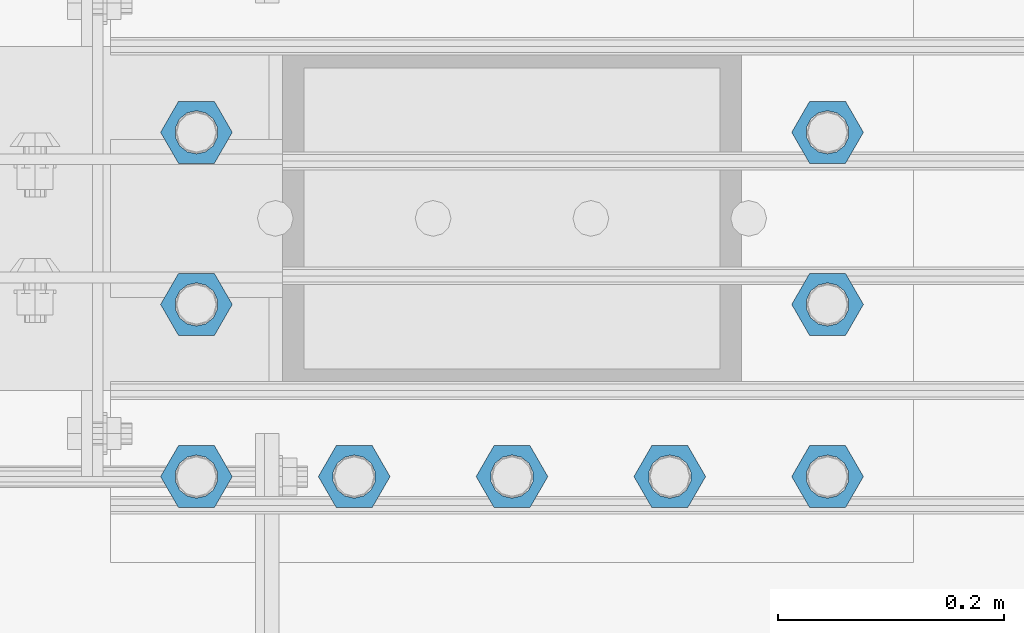
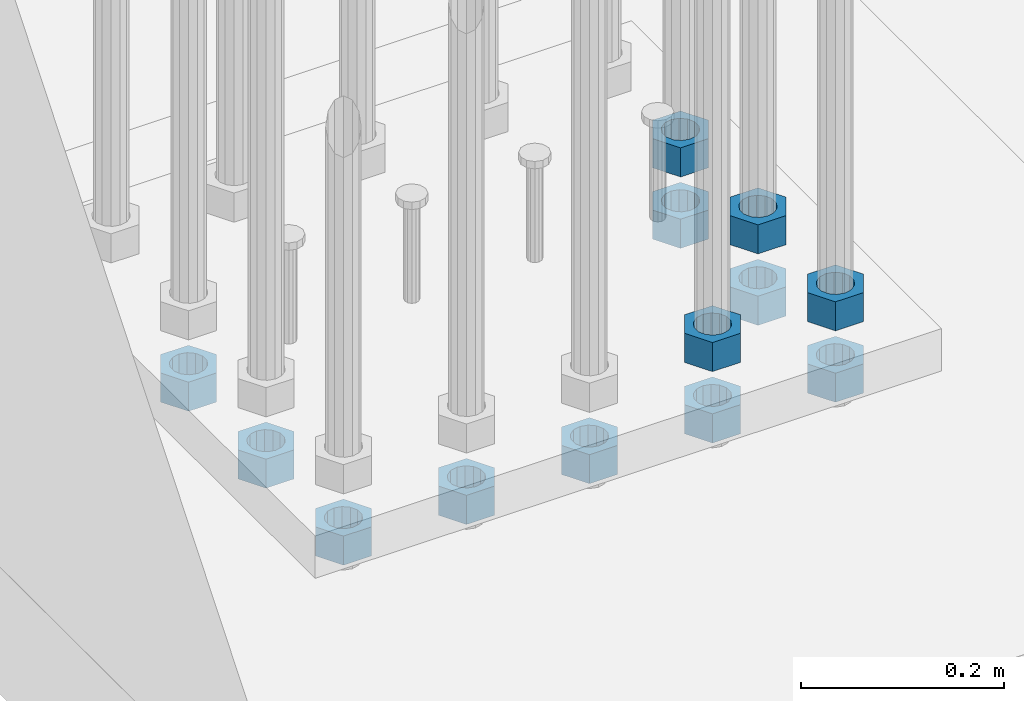
# One storey, part 1369 of 1876: 13 beams, 1 element without a shape of its own.
"""IFC2X3 building model written with IfcOpenShell, lengths in millimetres."""

from ifc_helpers import new_model, si_unit, frame, origin_with_axes, place, context, subcontext, project, spatial, faceted_brep, material, type_object, element, aggregate, save


model = new_model("IFC2X3")

# Units and contexts
model_context = context("Model", 3, precision=1e-05, world=origin_with_axes())
body_context = subcontext(model_context, "Body", "Model", "MODEL_VIEW")
ifc_project = project(units=[si_unit("LENGTHUNIT", "METRE", prefix="MILLI"), si_unit("AREAUNIT", "SQUARE_METRE"), si_unit("VOLUMEUNIT", "CUBIC_METRE"), si_unit("MASSUNIT", "GRAM", prefix="KILO"), si_unit("TIMEUNIT", "SECOND"), si_unit("PLANEANGLEUNIT", "RADIAN"), si_unit("SOLIDANGLEUNIT", "STERADIAN"), si_unit("THERMODYNAMICTEMPERATUREUNIT", "DEGREE_CELSIUS"), si_unit("LUMINOUSINTENSITYUNIT", "LUMEN")], contexts=[model_context])

# Site, building, storey
site_placement = place(None, origin_with_axes())
site = spatial("IfcSite", under=ifc_project, at=site_placement, CompositionType="ELEMENT")
building_placement = place(site_placement, origin_with_axes())
building = spatial("IfcBuilding", under=site, at=building_placement, Name="Undefined", CompositionType="ELEMENT")
storey_placement = place(building_placement, origin_with_axes())
storey = spatial("IfcBuildingStorey", under=building, at=storey_placement, Name="Undefined", CompositionType="ELEMENT", Elevation=0.0)

# Assembly, beams
assembly_placement = place(storey_placement, origin_with_axes())
assembly = element("IfcElementAssembly", 1, at=assembly_placement, inside=storey, Name="PLATE", AssemblyPlace="NOTDEFINED", PredefinedType="RIGID_FRAME")
ifc_material = material(Name="STEEL/A563")
beam_type = type_object("IfcBeamType", Name="1-3/8_HEAVY_HEX_NUT", PredefinedType="NOTDEFINED")
beam_1_placement = place(assembly_placement, frame((371.474990844726, -18313.3999755859, -701.675000762938), z_axis=(0.0, -1.0, 0.0), x_axis=(0.0, 0.0, -1.0)))
beam_1 = element("IfcBeam", 2, at=beam_1_placement, type_object=beam_type, material=ifc_material, Name="NUT", ObjectType="1-3/8_HEAVY_HEX_NUT", context=body_context, shape_type="Brep", body=[
    faceted_brep([(0.0, -31.75, 0.0), (0.0, -15.8800001144409, -27.5), (34.925, -15.8800001144409, -27.5), (34.925, -31.75, 0.0), (0.0, 15.8800001144409, -27.5), (34.925, 15.8800001144409, -27.5), (0.0, 31.75, 0.0), (34.925, 31.75, 0.0), (0.0, 15.8800001144409, 27.5), (34.925, 15.8800001144409, 27.5), (0.0, -15.8800001144409, 27.5), (34.925, -15.8800001144409, 27.5), (0.0, 0.0, 19.0499999999993), (0.0, 8.2654848991624, 17.1634562461559), (34.925, 8.26548489916252, 17.163456246155), (34.925, 0.0, 19.0499992370605), (0.0, 14.8938891445259, 11.8774802497237), (34.925, 14.8938891445259, 11.8774802497246), (0.0, 18.5723759832526, 4.2390236220981), (34.925, 18.5723759832528, 4.23902362209628), (0.0, 18.5723759832526, -4.2390236220981), (34.925, 18.5723759832528, -4.23902362209628), (0.0, 14.8938891445259, -11.8774802497237), (34.925, 14.8938891445259, -11.8774802497246), (0.0, 8.2654848991624, -17.1634562461568), (34.925, 8.26548489916252, -17.163456246155), (0.0, 0.0, -19.05), (34.925, 0.0, -19.0499992370605), (0.0, -8.2654848991624, -17.1634562461559), (34.925, -8.26548489916252, -17.163456246155), (0.0, -14.8938891445259, -11.8774802497237), (34.925, -14.8938891445259, -11.8774802497246), (0.0, -18.5723759832526, -4.2390236220981), (34.925, -18.5723759832528, -4.23902362209628), (0.0, -18.5723759832526, 4.2390236220981), (34.925, -18.5723759832528, 4.23902362209628), (0.0, -14.8938891445259, 11.8774802497237), (34.925, -14.8938891445259, 11.8774802497246), (0.0, -8.2654848991624, 17.1634562461568), (34.925, -8.26548489916252, 17.163456246155)], [[[0, 1, 2, 3]], [[1, 4, 5, 2]], [[4, 6, 7, 5]], [[6, 8, 9, 7]], [[8, 10, 11, 9]], [[10, 0, 3, 11]], [[12, 13, 14, 15]], [[13, 16, 17, 14]], [[16, 18, 19, 17]], [[18, 20, 21, 19]], [[20, 22, 23, 21]], [[22, 24, 25, 23]], [[24, 26, 27, 25]], [[26, 28, 29, 27]], [[28, 30, 31, 29]], [[30, 32, 33, 31]], [[32, 34, 35, 33]], [[34, 36, 37, 35]], [[36, 38, 39, 37]], [[38, 12, 15, 39]], [[5, 7, 9, 11, 3, 2], [17, 19, 21, 23, 25, 27, 29, 31, 33, 35, 37, 39, 15, 14]], [[10, 8, 6, 4, 1, 0], [38, 36, 34, 32, 30, 28, 26, 24, 22, 20, 18, 16, 13, 12]]]),
])
beam_2_placement = place(assembly_placement, frame((511.175003051757, -18008.599991862, -701.675000762938), z_axis=(0.0, -1.0, 0.0), x_axis=(0.0, 0.0, -1.0)))
beam_2 = element("IfcBeam", 3, at=beam_2_placement, type_object=beam_type, material=ifc_material, Name="NUT", ObjectType="1-3/8_HEAVY_HEX_NUT", context=body_context, shape_type="Brep", body=[
    faceted_brep([(0.0, -31.75, 0.0), (0.0, -15.8800001144409, -27.5), (34.925, -15.8800001144409, -27.5), (34.925, -31.75, 0.0), (0.0, 15.8800001144409, -27.5), (34.925, 15.8800001144409, -27.5), (0.0, 31.75, 0.0), (34.925, 31.75, 0.0), (0.0, 15.8800001144409, 27.5), (34.925, 15.8800001144409, 27.5), (0.0, -15.8800001144409, 27.5), (34.925, -15.8800001144409, 27.5), (0.0, 0.0, 19.0499999999993), (0.0, 8.2654848991624, 17.1634562461559), (34.925, 8.26548489916252, 17.163456246155), (34.925, 0.0, 19.0499992370605), (0.0, 14.8938891445259, 11.8774802497237), (34.925, 14.8938891445259, 11.8774802497246), (0.0, 18.5723759832526, 4.2390236220981), (34.925, 18.5723759832528, 4.23902362209628), (0.0, 18.5723759832526, -4.2390236220981), (34.925, 18.5723759832528, -4.23902362209628), (0.0, 14.8938891445259, -11.8774802497237), (34.925, 14.8938891445259, -11.8774802497246), (0.0, 8.2654848991624, -17.1634562461568), (34.925, 8.26548489916252, -17.163456246155), (0.0, 0.0, -19.05), (34.925, 0.0, -19.0499992370605), (0.0, -8.2654848991624, -17.1634562461559), (34.925, -8.26548489916252, -17.163456246155), (0.0, -14.8938891445259, -11.8774802497237), (34.925, -14.8938891445259, -11.8774802497246), (0.0, -18.5723759832526, -4.2390236220981), (34.925, -18.5723759832528, -4.23902362209628), (0.0, -18.5723759832526, 4.2390236220981), (34.925, -18.5723759832528, 4.23902362209628), (0.0, -14.8938891445259, 11.8774802497237), (34.925, -14.8938891445259, 11.8774802497246), (0.0, -8.2654848991624, 17.1634562461568), (34.925, -8.26548489916252, 17.163456246155)], [[[0, 1, 2, 3]], [[1, 4, 5, 2]], [[4, 6, 7, 5]], [[6, 8, 9, 7]], [[8, 10, 11, 9]], [[10, 0, 3, 11]], [[12, 13, 14, 15]], [[13, 16, 17, 14]], [[16, 18, 19, 17]], [[18, 20, 21, 19]], [[20, 22, 23, 21]], [[22, 24, 25, 23]], [[24, 26, 27, 25]], [[26, 28, 29, 27]], [[28, 30, 31, 29]], [[30, 32, 33, 31]], [[32, 34, 35, 33]], [[34, 36, 37, 35]], [[36, 38, 39, 37]], [[38, 12, 15, 39]], [[5, 7, 9, 11, 3, 2], [17, 19, 21, 23, 25, 27, 29, 31, 33, 35, 37, 39, 15, 14]], [[10, 8, 6, 4, 1, 0], [38, 36, 34, 32, 30, 28, 26, 24, 22, 20, 18, 16, 13, 12]]]),
])
beam_3_placement = place(assembly_placement, frame((511.175003051757, -18160.999983724, -701.675000762938), z_axis=(0.0, -1.0, 0.0), x_axis=(0.0, 0.0, -1.0)))
beam_3 = element("IfcBeam", 4, at=beam_3_placement, type_object=beam_type, material=ifc_material, Name="NUT", ObjectType="1-3/8_HEAVY_HEX_NUT", context=body_context, shape_type="Brep", body=[
    faceted_brep([(0.0, -31.75, 0.0), (0.0, -15.8800001144409, -27.5), (34.925, -15.8800001144409, -27.5), (34.925, -31.75, 0.0), (0.0, 15.8800001144409, -27.5), (34.925, 15.8800001144409, -27.5), (0.0, 31.75, 0.0), (34.925, 31.75, 0.0), (0.0, 15.8800001144409, 27.5), (34.925, 15.8800001144409, 27.5), (0.0, -15.8800001144409, 27.5), (34.925, -15.8800001144409, 27.5), (0.0, 0.0, 19.0499999999993), (0.0, 8.2654848991624, 17.1634562461559), (34.925, 8.26548489916252, 17.163456246155), (34.925, 0.0, 19.0499992370605), (0.0, 14.8938891445259, 11.8774802497237), (34.925, 14.8938891445259, 11.8774802497246), (0.0, 18.5723759832526, 4.2390236220981), (34.925, 18.5723759832528, 4.23902362209628), (0.0, 18.5723759832526, -4.2390236220981), (34.925, 18.5723759832528, -4.23902362209628), (0.0, 14.8938891445259, -11.8774802497237), (34.925, 14.8938891445259, -11.8774802497246), (0.0, 8.2654848991624, -17.1634562461568), (34.925, 8.26548489916252, -17.163456246155), (0.0, 0.0, -19.05), (34.925, 0.0, -19.0499992370605), (0.0, -8.2654848991624, -17.1634562461559), (34.925, -8.26548489916252, -17.163456246155), (0.0, -14.8938891445259, -11.8774802497237), (34.925, -14.8938891445259, -11.8774802497246), (0.0, -18.5723759832526, -4.2390236220981), (34.925, -18.5723759832528, -4.23902362209628), (0.0, -18.5723759832526, 4.2390236220981), (34.925, -18.5723759832528, 4.23902362209628), (0.0, -14.8938891445259, 11.8774802497237), (34.925, -14.8938891445259, 11.8774802497246), (0.0, -8.2654848991624, 17.1634562461568), (34.925, -8.26548489916252, 17.163456246155)], [[[0, 1, 2, 3]], [[1, 4, 5, 2]], [[4, 6, 7, 5]], [[6, 8, 9, 7]], [[8, 10, 11, 9]], [[10, 0, 3, 11]], [[12, 13, 14, 15]], [[13, 16, 17, 14]], [[16, 18, 19, 17]], [[18, 20, 21, 19]], [[20, 22, 23, 21]], [[22, 24, 25, 23]], [[24, 26, 27, 25]], [[26, 28, 29, 27]], [[28, 30, 31, 29]], [[30, 32, 33, 31]], [[32, 34, 35, 33]], [[34, 36, 37, 35]], [[36, 38, 39, 37]], [[38, 12, 15, 39]], [[5, 7, 9, 11, 3, 2], [17, 19, 21, 23, 25, 27, 29, 31, 33, 35, 37, 39, 15, 14]], [[10, 8, 6, 4, 1, 0], [38, 36, 34, 32, 30, 28, 26, 24, 22, 20, 18, 16, 13, 12]]]),
])
beam_4_placement = place(assembly_placement, frame((511.175003051757, -18313.3999755859, -701.675000762938), z_axis=(0.0, -1.0, 0.0), x_axis=(0.0, 0.0, -1.0)))
beam_4 = element("IfcBeam", 5, at=beam_4_placement, type_object=beam_type, material=ifc_material, Name="NUT", ObjectType="1-3/8_HEAVY_HEX_NUT", context=body_context, shape_type="Brep", body=[
    faceted_brep([(0.0, -31.75, 0.0), (0.0, -15.8800001144409, -27.5), (34.925, -15.8800001144409, -27.5), (34.925, -31.75, 0.0), (0.0, 15.8800001144409, -27.5), (34.925, 15.8800001144409, -27.5), (0.0, 31.75, 0.0), (34.925, 31.75, 0.0), (0.0, 15.8800001144409, 27.5), (34.925, 15.8800001144409, 27.5), (0.0, -15.8800001144409, 27.5), (34.925, -15.8800001144409, 27.5), (0.0, 0.0, 19.0499999999993), (0.0, 8.2654848991624, 17.1634562461559), (34.925, 8.26548489916252, 17.163456246155), (34.925, 0.0, 19.0499992370605), (0.0, 14.8938891445259, 11.8774802497237), (34.925, 14.8938891445259, 11.8774802497246), (0.0, 18.5723759832526, 4.2390236220981), (34.925, 18.5723759832528, 4.23902362209628), (0.0, 18.5723759832526, -4.2390236220981), (34.925, 18.5723759832528, -4.23902362209628), (0.0, 14.8938891445259, -11.8774802497237), (34.925, 14.8938891445259, -11.8774802497246), (0.0, 8.2654848991624, -17.1634562461568), (34.925, 8.26548489916252, -17.163456246155), (0.0, 0.0, -19.05), (34.925, 0.0, -19.0499992370605), (0.0, -8.2654848991624, -17.1634562461559), (34.925, -8.26548489916252, -17.163456246155), (0.0, -14.8938891445259, -11.8774802497237), (34.925, -14.8938891445259, -11.8774802497246), (0.0, -18.5723759832526, -4.2390236220981), (34.925, -18.5723759832528, -4.23902362209628), (0.0, -18.5723759832526, 4.2390236220981), (34.925, -18.5723759832528, 4.23902362209628), (0.0, -14.8938891445259, 11.8774802497237), (34.925, -14.8938891445259, 11.8774802497246), (0.0, -8.2654848991624, 17.1634562461568), (34.925, -8.26548489916252, 17.163456246155)], [[[0, 1, 2, 3]], [[1, 4, 5, 2]], [[4, 6, 7, 5]], [[6, 8, 9, 7]], [[8, 10, 11, 9]], [[10, 0, 3, 11]], [[12, 13, 14, 15]], [[13, 16, 17, 14]], [[16, 18, 19, 17]], [[18, 20, 21, 19]], [[20, 22, 23, 21]], [[22, 24, 25, 23]], [[24, 26, 27, 25]], [[26, 28, 29, 27]], [[28, 30, 31, 29]], [[30, 32, 33, 31]], [[32, 34, 35, 33]], [[34, 36, 37, 35]], [[36, 38, 39, 37]], [[38, 12, 15, 39]], [[5, 7, 9, 11, 3, 2], [17, 19, 21, 23, 25, 27, 29, 31, 33, 35, 37, 39, 15, 14]], [[10, 8, 6, 4, 1, 0], [38, 36, 34, 32, 30, 28, 26, 24, 22, 20, 18, 16, 13, 12]]]),
])
beam_5_placement = place(assembly_placement, frame((-47.6250122070322, -18008.599991862, -787.400000000001), z_axis=(0.0, -1.0, 0.0), x_axis=(0.0, 0.0, -1.0)))
beam_5 = element("IfcBeam", 6, at=beam_5_placement, type_object=beam_type, material=ifc_material, Name="NUT", ObjectType="1-3/8_HEAVY_HEX_NUT", context=body_context, shape_type="Brep", body=[
    faceted_brep([(0.0, -31.75, 0.0), (0.0, -15.8800001144409, -27.5), (34.925, -15.8800001144409, -27.5), (34.925, -31.75, 0.0), (0.0, 15.8800001144409, -27.5), (34.925, 15.8800001144409, -27.5), (0.0, 31.75, 0.0), (34.925, 31.75, 0.0), (0.0, 15.8800001144409, 27.5), (34.925, 15.8800001144409, 27.5), (0.0, -15.8800001144409, 27.5), (34.925, -15.8800001144409, 27.5), (0.0, 0.0, 19.0499999999993), (0.0, 8.2654848991624, 17.1634562461559), (34.925, 8.26548489916252, 17.163456246155), (34.925, 0.0, 19.0499992370605), (0.0, 14.8938891445259, 11.8774802497237), (34.925, 14.8938891445259, 11.8774802497246), (0.0, 18.5723759832526, 4.2390236220981), (34.925, 18.5723759832528, 4.23902362209628), (0.0, 18.5723759832526, -4.2390236220981), (34.925, 18.5723759832528, -4.23902362209628), (0.0, 14.8938891445259, -11.8774802497237), (34.925, 14.8938891445259, -11.8774802497246), (0.0, 8.2654848991624, -17.1634562461568), (34.925, 8.26548489916252, -17.163456246155), (0.0, 0.0, -19.05), (34.925, 0.0, -19.0499992370605), (0.0, -8.2654848991624, -17.1634562461559), (34.925, -8.26548489916252, -17.163456246155), (0.0, -14.8938891445259, -11.8774802497237), (34.925, -14.8938891445259, -11.8774802497246), (0.0, -18.5723759832526, -4.2390236220981), (34.925, -18.5723759832528, -4.23902362209628), (0.0, -18.5723759832526, 4.2390236220981), (34.925, -18.5723759832528, 4.23902362209628), (0.0, -14.8938891445259, 11.8774802497237), (34.925, -14.8938891445259, 11.8774802497246), (0.0, -8.2654848991624, 17.1634562461568), (34.925, -8.26548489916252, 17.163456246155)], [[[0, 1, 2, 3]], [[1, 4, 5, 2]], [[4, 6, 7, 5]], [[6, 8, 9, 7]], [[8, 10, 11, 9]], [[10, 0, 3, 11]], [[12, 13, 14, 15]], [[13, 16, 17, 14]], [[16, 18, 19, 17]], [[18, 20, 21, 19]], [[20, 22, 23, 21]], [[22, 24, 25, 23]], [[24, 26, 27, 25]], [[26, 28, 29, 27]], [[28, 30, 31, 29]], [[30, 32, 33, 31]], [[32, 34, 35, 33]], [[34, 36, 37, 35]], [[36, 38, 39, 37]], [[38, 12, 15, 39]], [[5, 7, 9, 11, 3, 2], [17, 19, 21, 23, 25, 27, 29, 31, 33, 35, 37, 39, 15, 14]], [[10, 8, 6, 4, 1, 0], [38, 36, 34, 32, 30, 28, 26, 24, 22, 20, 18, 16, 13, 12]]]),
])
beam_6_placement = place(assembly_placement, frame((-47.6250122070322, -18160.999983724, -787.400000000001), z_axis=(0.0, -1.0, 0.0), x_axis=(0.0, 0.0, -1.0)))
beam_6 = element("IfcBeam", 7, at=beam_6_placement, type_object=beam_type, material=ifc_material, Name="NUT", ObjectType="1-3/8_HEAVY_HEX_NUT", context=body_context, shape_type="Brep", body=[
    faceted_brep([(0.0, -31.75, 0.0), (0.0, -15.8800001144409, -27.5), (34.925, -15.8800001144409, -27.5), (34.925, -31.75, 0.0), (0.0, 15.8800001144409, -27.5), (34.925, 15.8800001144409, -27.5), (0.0, 31.75, 0.0), (34.925, 31.75, 0.0), (0.0, 15.8800001144409, 27.5), (34.925, 15.8800001144409, 27.5), (0.0, -15.8800001144409, 27.5), (34.925, -15.8800001144409, 27.5), (0.0, 0.0, 19.0499999999993), (0.0, 8.2654848991624, 17.1634562461559), (34.925, 8.26548489916252, 17.163456246155), (34.925, 0.0, 19.0499992370605), (0.0, 14.8938891445259, 11.8774802497237), (34.925, 14.8938891445259, 11.8774802497246), (0.0, 18.5723759832526, 4.2390236220981), (34.925, 18.5723759832528, 4.23902362209628), (0.0, 18.5723759832526, -4.2390236220981), (34.925, 18.5723759832528, -4.23902362209628), (0.0, 14.8938891445259, -11.8774802497237), (34.925, 14.8938891445259, -11.8774802497246), (0.0, 8.2654848991624, -17.1634562461568), (34.925, 8.26548489916252, -17.163456246155), (0.0, 0.0, -19.05), (34.925, 0.0, -19.0499992370605), (0.0, -8.2654848991624, -17.1634562461559), (34.925, -8.26548489916252, -17.163456246155), (0.0, -14.8938891445259, -11.8774802497237), (34.925, -14.8938891445259, -11.8774802497246), (0.0, -18.5723759832526, -4.2390236220981), (34.925, -18.5723759832528, -4.23902362209628), (0.0, -18.5723759832526, 4.2390236220981), (34.925, -18.5723759832528, 4.23902362209628), (0.0, -14.8938891445259, 11.8774802497237), (34.925, -14.8938891445259, 11.8774802497246), (0.0, -8.2654848991624, 17.1634562461568), (34.925, -8.26548489916252, 17.163456246155)], [[[0, 1, 2, 3]], [[1, 4, 5, 2]], [[4, 6, 7, 5]], [[6, 8, 9, 7]], [[8, 10, 11, 9]], [[10, 0, 3, 11]], [[12, 13, 14, 15]], [[13, 16, 17, 14]], [[16, 18, 19, 17]], [[18, 20, 21, 19]], [[20, 22, 23, 21]], [[22, 24, 25, 23]], [[24, 26, 27, 25]], [[26, 28, 29, 27]], [[28, 30, 31, 29]], [[30, 32, 33, 31]], [[32, 34, 35, 33]], [[34, 36, 37, 35]], [[36, 38, 39, 37]], [[38, 12, 15, 39]], [[5, 7, 9, 11, 3, 2], [17, 19, 21, 23, 25, 27, 29, 31, 33, 35, 37, 39, 15, 14]], [[10, 8, 6, 4, 1, 0], [38, 36, 34, 32, 30, 28, 26, 24, 22, 20, 18, 16, 13, 12]]]),
])
beam_7_placement = place(assembly_placement, frame((-47.6250122070322, -18313.3999755859, -787.400000000001), z_axis=(0.0, -1.0, 0.0), x_axis=(0.0, 0.0, -1.0)))
beam_7 = element("IfcBeam", 8, at=beam_7_placement, type_object=beam_type, material=ifc_material, Name="NUT", ObjectType="1-3/8_HEAVY_HEX_NUT", context=body_context, shape_type="Brep", body=[
    faceted_brep([(0.0, -31.75, 0.0), (0.0, -15.8800001144409, -27.5), (34.925, -15.8800001144409, -27.5), (34.925, -31.75, 0.0), (0.0, 15.8800001144409, -27.5), (34.925, 15.8800001144409, -27.5), (0.0, 31.75, 0.0), (34.925, 31.75, 0.0), (0.0, 15.8800001144409, 27.5), (34.925, 15.8800001144409, 27.5), (0.0, -15.8800001144409, 27.5), (34.925, -15.8800001144409, 27.5), (0.0, 0.0, 19.0499999999993), (0.0, 8.2654848991624, 17.1634562461559), (34.925, 8.26548489916252, 17.163456246155), (34.925, 0.0, 19.0499992370605), (0.0, 14.8938891445259, 11.8774802497237), (34.925, 14.8938891445259, 11.8774802497246), (0.0, 18.5723759832526, 4.2390236220981), (34.925, 18.5723759832528, 4.23902362209628), (0.0, 18.5723759832526, -4.2390236220981), (34.925, 18.5723759832528, -4.23902362209628), (0.0, 14.8938891445259, -11.8774802497237), (34.925, 14.8938891445259, -11.8774802497246), (0.0, 8.2654848991624, -17.1634562461568), (34.925, 8.26548489916252, -17.163456246155), (0.0, 0.0, -19.05), (34.925, 0.0, -19.0499992370605), (0.0, -8.2654848991624, -17.1634562461559), (34.925, -8.26548489916252, -17.163456246155), (0.0, -14.8938891445259, -11.8774802497237), (34.925, -14.8938891445259, -11.8774802497246), (0.0, -18.5723759832526, -4.2390236220981), (34.925, -18.5723759832528, -4.23902362209628), (0.0, -18.5723759832526, 4.2390236220981), (34.925, -18.5723759832528, 4.23902362209628), (0.0, -14.8938891445259, 11.8774802497237), (34.925, -14.8938891445259, 11.8774802497246), (0.0, -8.2654848991624, 17.1634562461568), (34.925, -8.26548489916252, 17.163456246155)], [[[0, 1, 2, 3]], [[1, 4, 5, 2]], [[4, 6, 7, 5]], [[6, 8, 9, 7]], [[8, 10, 11, 9]], [[10, 0, 3, 11]], [[12, 13, 14, 15]], [[13, 16, 17, 14]], [[16, 18, 19, 17]], [[18, 20, 21, 19]], [[20, 22, 23, 21]], [[22, 24, 25, 23]], [[24, 26, 27, 25]], [[26, 28, 29, 27]], [[28, 30, 31, 29]], [[30, 32, 33, 31]], [[32, 34, 35, 33]], [[34, 36, 37, 35]], [[36, 38, 39, 37]], [[38, 12, 15, 39]], [[5, 7, 9, 11, 3, 2], [17, 19, 21, 23, 25, 27, 29, 31, 33, 35, 37, 39, 15, 14]], [[10, 8, 6, 4, 1, 0], [38, 36, 34, 32, 30, 28, 26, 24, 22, 20, 18, 16, 13, 12]]]),
])
beam_8_placement = place(assembly_placement, frame((92.0749877929678, -18313.3999755859, -787.400000000001), z_axis=(0.0, -1.0, 0.0), x_axis=(0.0, 0.0, -1.0)))
beam_8 = element("IfcBeam", 9, at=beam_8_placement, type_object=beam_type, material=ifc_material, Name="NUT", ObjectType="1-3/8_HEAVY_HEX_NUT", context=body_context, shape_type="Brep", body=[
    faceted_brep([(0.0, -31.75, 0.0), (0.0, -15.8800001144409, -27.5), (34.925, -15.8800001144409, -27.5), (34.925, -31.75, 0.0), (0.0, 15.8800001144409, -27.5), (34.925, 15.8800001144409, -27.5), (0.0, 31.75, 0.0), (34.925, 31.75, 0.0), (0.0, 15.8800001144409, 27.5), (34.925, 15.8800001144409, 27.5), (0.0, -15.8800001144409, 27.5), (34.925, -15.8800001144409, 27.5), (0.0, 0.0, 19.0499999999993), (0.0, 8.2654848991624, 17.1634562461559), (34.925, 8.26548489916252, 17.163456246155), (34.925, 0.0, 19.0499992370605), (0.0, 14.8938891445259, 11.8774802497237), (34.925, 14.8938891445259, 11.8774802497246), (0.0, 18.5723759832526, 4.2390236220981), (34.925, 18.5723759832528, 4.23902362209628), (0.0, 18.5723759832526, -4.2390236220981), (34.925, 18.5723759832528, -4.23902362209628), (0.0, 14.8938891445259, -11.8774802497237), (34.925, 14.8938891445259, -11.8774802497246), (0.0, 8.2654848991624, -17.1634562461568), (34.925, 8.26548489916252, -17.163456246155), (0.0, 0.0, -19.05), (34.925, 0.0, -19.0499992370605), (0.0, -8.2654848991624, -17.1634562461559), (34.925, -8.26548489916252, -17.163456246155), (0.0, -14.8938891445259, -11.8774802497237), (34.925, -14.8938891445259, -11.8774802497246), (0.0, -18.5723759832526, -4.2390236220981), (34.925, -18.5723759832528, -4.23902362209628), (0.0, -18.5723759832526, 4.2390236220981), (34.925, -18.5723759832528, 4.23902362209628), (0.0, -14.8938891445259, 11.8774802497237), (34.925, -14.8938891445259, 11.8774802497246), (0.0, -8.2654848991624, 17.1634562461568), (34.925, -8.26548489916252, 17.163456246155)], [[[0, 1, 2, 3]], [[1, 4, 5, 2]], [[4, 6, 7, 5]], [[6, 8, 9, 7]], [[8, 10, 11, 9]], [[10, 0, 3, 11]], [[12, 13, 14, 15]], [[13, 16, 17, 14]], [[16, 18, 19, 17]], [[18, 20, 21, 19]], [[20, 22, 23, 21]], [[22, 24, 25, 23]], [[24, 26, 27, 25]], [[26, 28, 29, 27]], [[28, 30, 31, 29]], [[30, 32, 33, 31]], [[32, 34, 35, 33]], [[34, 36, 37, 35]], [[36, 38, 39, 37]], [[38, 12, 15, 39]], [[5, 7, 9, 11, 3, 2], [17, 19, 21, 23, 25, 27, 29, 31, 33, 35, 37, 39, 15, 14]], [[10, 8, 6, 4, 1, 0], [38, 36, 34, 32, 30, 28, 26, 24, 22, 20, 18, 16, 13, 12]]]),
])
beam_9_placement = place(assembly_placement, frame((231.774987792968, -18313.3999755859, -787.400000000001), z_axis=(0.0, -1.0, 0.0), x_axis=(0.0, 0.0, -1.0)))
beam_9 = element("IfcBeam", 10, at=beam_9_placement, type_object=beam_type, material=ifc_material, Name="NUT", ObjectType="1-3/8_HEAVY_HEX_NUT", context=body_context, shape_type="Brep", body=[
    faceted_brep([(0.0, -31.75, 0.0), (0.0, -15.8800001144409, -27.5), (34.925, -15.8800001144409, -27.5), (34.925, -31.75, 0.0), (0.0, 15.8800001144409, -27.5), (34.925, 15.8800001144409, -27.5), (0.0, 31.75, 0.0), (34.925, 31.75, 0.0), (0.0, 15.8800001144409, 27.5), (34.925, 15.8800001144409, 27.5), (0.0, -15.8800001144409, 27.5), (34.925, -15.8800001144409, 27.5), (0.0, 0.0, 19.0499999999993), (0.0, 8.2654848991624, 17.1634562461559), (34.925, 8.26548489916252, 17.163456246155), (34.925, 0.0, 19.0499992370605), (0.0, 14.8938891445259, 11.8774802497237), (34.925, 14.8938891445259, 11.8774802497246), (0.0, 18.5723759832526, 4.2390236220981), (34.925, 18.5723759832528, 4.23902362209628), (0.0, 18.5723759832526, -4.2390236220981), (34.925, 18.5723759832528, -4.23902362209628), (0.0, 14.8938891445259, -11.8774802497237), (34.925, 14.8938891445259, -11.8774802497246), (0.0, 8.2654848991624, -17.1634562461568), (34.925, 8.26548489916252, -17.163456246155), (0.0, 0.0, -19.05), (34.925, 0.0, -19.0499992370605), (0.0, -8.2654848991624, -17.1634562461559), (34.925, -8.26548489916252, -17.163456246155), (0.0, -14.8938891445259, -11.8774802497237), (34.925, -14.8938891445259, -11.8774802497246), (0.0, -18.5723759832526, -4.2390236220981), (34.925, -18.5723759832528, -4.23902362209628), (0.0, -18.5723759832526, 4.2390236220981), (34.925, -18.5723759832528, 4.23902362209628), (0.0, -14.8938891445259, 11.8774802497237), (34.925, -14.8938891445259, 11.8774802497246), (0.0, -8.2654848991624, 17.1634562461568), (34.925, -8.26548489916252, 17.163456246155)], [[[0, 1, 2, 3]], [[1, 4, 5, 2]], [[4, 6, 7, 5]], [[6, 8, 9, 7]], [[8, 10, 11, 9]], [[10, 0, 3, 11]], [[12, 13, 14, 15]], [[13, 16, 17, 14]], [[16, 18, 19, 17]], [[18, 20, 21, 19]], [[20, 22, 23, 21]], [[22, 24, 25, 23]], [[24, 26, 27, 25]], [[26, 28, 29, 27]], [[28, 30, 31, 29]], [[30, 32, 33, 31]], [[32, 34, 35, 33]], [[34, 36, 37, 35]], [[36, 38, 39, 37]], [[38, 12, 15, 39]], [[5, 7, 9, 11, 3, 2], [17, 19, 21, 23, 25, 27, 29, 31, 33, 35, 37, 39, 15, 14]], [[10, 8, 6, 4, 1, 0], [38, 36, 34, 32, 30, 28, 26, 24, 22, 20, 18, 16, 13, 12]]]),
])
beam_10_placement = place(assembly_placement, frame((371.474987792968, -18313.3999755859, -787.400000000001), z_axis=(0.0, -1.0, 0.0), x_axis=(0.0, 0.0, -1.0)))
beam_10 = element("IfcBeam", 11, at=beam_10_placement, type_object=beam_type, material=ifc_material, Name="NUT", ObjectType="1-3/8_HEAVY_HEX_NUT", context=body_context, shape_type="Brep", body=[
    faceted_brep([(0.0, -31.75, 0.0), (0.0, -15.8800001144409, -27.5), (34.925, -15.8800001144409, -27.5), (34.925, -31.75, 0.0), (0.0, 15.8800001144409, -27.5), (34.925, 15.8800001144409, -27.5), (0.0, 31.75, 0.0), (34.925, 31.75, 0.0), (0.0, 15.8800001144409, 27.5), (34.925, 15.8800001144409, 27.5), (0.0, -15.8800001144409, 27.5), (34.925, -15.8800001144409, 27.5), (0.0, 0.0, 19.0499999999993), (0.0, 8.2654848991624, 17.1634562461559), (34.925, 8.26548489916252, 17.163456246155), (34.925, 0.0, 19.0499992370605), (0.0, 14.8938891445259, 11.8774802497237), (34.925, 14.8938891445259, 11.8774802497246), (0.0, 18.5723759832526, 4.2390236220981), (34.925, 18.5723759832528, 4.23902362209628), (0.0, 18.5723759832526, -4.2390236220981), (34.925, 18.5723759832528, -4.23902362209628), (0.0, 14.8938891445259, -11.8774802497237), (34.925, 14.8938891445259, -11.8774802497246), (0.0, 8.2654848991624, -17.1634562461568), (34.925, 8.26548489916252, -17.163456246155), (0.0, 0.0, -19.05), (34.925, 0.0, -19.0499992370605), (0.0, -8.2654848991624, -17.1634562461559), (34.925, -8.26548489916252, -17.163456246155), (0.0, -14.8938891445259, -11.8774802497237), (34.925, -14.8938891445259, -11.8774802497246), (0.0, -18.5723759832526, -4.2390236220981), (34.925, -18.5723759832528, -4.23902362209628), (0.0, -18.5723759832526, 4.2390236220981), (34.925, -18.5723759832528, 4.23902362209628), (0.0, -14.8938891445259, 11.8774802497237), (34.925, -14.8938891445259, 11.8774802497246), (0.0, -8.2654848991624, 17.1634562461568), (34.925, -8.26548489916252, 17.163456246155)], [[[0, 1, 2, 3]], [[1, 4, 5, 2]], [[4, 6, 7, 5]], [[6, 8, 9, 7]], [[8, 10, 11, 9]], [[10, 0, 3, 11]], [[12, 13, 14, 15]], [[13, 16, 17, 14]], [[16, 18, 19, 17]], [[18, 20, 21, 19]], [[20, 22, 23, 21]], [[22, 24, 25, 23]], [[24, 26, 27, 25]], [[26, 28, 29, 27]], [[28, 30, 31, 29]], [[30, 32, 33, 31]], [[32, 34, 35, 33]], [[34, 36, 37, 35]], [[36, 38, 39, 37]], [[38, 12, 15, 39]], [[5, 7, 9, 11, 3, 2], [17, 19, 21, 23, 25, 27, 29, 31, 33, 35, 37, 39, 15, 14]], [[10, 8, 6, 4, 1, 0], [38, 36, 34, 32, 30, 28, 26, 24, 22, 20, 18, 16, 13, 12]]]),
])
beam_11_placement = place(assembly_placement, frame((511.174999999999, -18008.599991862, -787.400000000001), z_axis=(0.0, -1.0, 0.0), x_axis=(0.0, 0.0, -1.0)))
beam_11 = element("IfcBeam", 12, at=beam_11_placement, type_object=beam_type, material=ifc_material, Name="NUT", ObjectType="1-3/8_HEAVY_HEX_NUT", context=body_context, shape_type="Brep", body=[
    faceted_brep([(0.0, -31.75, 0.0), (0.0, -15.8800001144409, -27.5), (34.925, -15.8800001144409, -27.5), (34.925, -31.75, 0.0), (0.0, 15.8800001144409, -27.5), (34.925, 15.8800001144409, -27.5), (0.0, 31.75, 0.0), (34.925, 31.75, 0.0), (0.0, 15.8800001144409, 27.5), (34.925, 15.8800001144409, 27.5), (0.0, -15.8800001144409, 27.5), (34.925, -15.8800001144409, 27.5), (0.0, 0.0, 19.0499999999993), (0.0, 8.2654848991624, 17.1634562461559), (34.925, 8.26548489916252, 17.163456246155), (34.925, 0.0, 19.0499992370605), (0.0, 14.8938891445259, 11.8774802497237), (34.925, 14.8938891445259, 11.8774802497246), (0.0, 18.5723759832526, 4.2390236220981), (34.925, 18.5723759832528, 4.23902362209628), (0.0, 18.5723759832526, -4.2390236220981), (34.925, 18.5723759832528, -4.23902362209628), (0.0, 14.8938891445259, -11.8774802497237), (34.925, 14.8938891445259, -11.8774802497246), (0.0, 8.2654848991624, -17.1634562461568), (34.925, 8.26548489916252, -17.163456246155), (0.0, 0.0, -19.05), (34.925, 0.0, -19.0499992370605), (0.0, -8.2654848991624, -17.1634562461559), (34.925, -8.26548489916252, -17.163456246155), (0.0, -14.8938891445259, -11.8774802497237), (34.925, -14.8938891445259, -11.8774802497246), (0.0, -18.5723759832526, -4.2390236220981), (34.925, -18.5723759832528, -4.23902362209628), (0.0, -18.5723759832526, 4.2390236220981), (34.925, -18.5723759832528, 4.23902362209628), (0.0, -14.8938891445259, 11.8774802497237), (34.925, -14.8938891445259, 11.8774802497246), (0.0, -8.2654848991624, 17.1634562461568), (34.925, -8.26548489916252, 17.163456246155)], [[[0, 1, 2, 3]], [[1, 4, 5, 2]], [[4, 6, 7, 5]], [[6, 8, 9, 7]], [[8, 10, 11, 9]], [[10, 0, 3, 11]], [[12, 13, 14, 15]], [[13, 16, 17, 14]], [[16, 18, 19, 17]], [[18, 20, 21, 19]], [[20, 22, 23, 21]], [[22, 24, 25, 23]], [[24, 26, 27, 25]], [[26, 28, 29, 27]], [[28, 30, 31, 29]], [[30, 32, 33, 31]], [[32, 34, 35, 33]], [[34, 36, 37, 35]], [[36, 38, 39, 37]], [[38, 12, 15, 39]], [[5, 7, 9, 11, 3, 2], [17, 19, 21, 23, 25, 27, 29, 31, 33, 35, 37, 39, 15, 14]], [[10, 8, 6, 4, 1, 0], [38, 36, 34, 32, 30, 28, 26, 24, 22, 20, 18, 16, 13, 12]]]),
])
beam_12_placement = place(assembly_placement, frame((511.174999999999, -18160.999983724, -787.400000000001), z_axis=(0.0, -1.0, 0.0), x_axis=(0.0, 0.0, -1.0)))
beam_12 = element("IfcBeam", 13, at=beam_12_placement, type_object=beam_type, material=ifc_material, Name="NUT", ObjectType="1-3/8_HEAVY_HEX_NUT", context=body_context, shape_type="Brep", body=[
    faceted_brep([(0.0, -31.75, 0.0), (0.0, -15.8800001144409, -27.5), (34.925, -15.8800001144409, -27.5), (34.925, -31.75, 0.0), (0.0, 15.8800001144409, -27.5), (34.925, 15.8800001144409, -27.5), (0.0, 31.75, 0.0), (34.925, 31.75, 0.0), (0.0, 15.8800001144409, 27.5), (34.925, 15.8800001144409, 27.5), (0.0, -15.8800001144409, 27.5), (34.925, -15.8800001144409, 27.5), (0.0, 0.0, 19.0499999999993), (0.0, 8.2654848991624, 17.1634562461559), (34.925, 8.26548489916252, 17.163456246155), (34.925, 0.0, 19.0499992370605), (0.0, 14.8938891445259, 11.8774802497237), (34.925, 14.8938891445259, 11.8774802497246), (0.0, 18.5723759832526, 4.2390236220981), (34.925, 18.5723759832528, 4.23902362209628), (0.0, 18.5723759832526, -4.2390236220981), (34.925, 18.5723759832528, -4.23902362209628), (0.0, 14.8938891445259, -11.8774802497237), (34.925, 14.8938891445259, -11.8774802497246), (0.0, 8.2654848991624, -17.1634562461568), (34.925, 8.26548489916252, -17.163456246155), (0.0, 0.0, -19.05), (34.925, 0.0, -19.0499992370605), (0.0, -8.2654848991624, -17.1634562461559), (34.925, -8.26548489916252, -17.163456246155), (0.0, -14.8938891445259, -11.8774802497237), (34.925, -14.8938891445259, -11.8774802497246), (0.0, -18.5723759832526, -4.2390236220981), (34.925, -18.5723759832528, -4.23902362209628), (0.0, -18.5723759832526, 4.2390236220981), (34.925, -18.5723759832528, 4.23902362209628), (0.0, -14.8938891445259, 11.8774802497237), (34.925, -14.8938891445259, 11.8774802497246), (0.0, -8.2654848991624, 17.1634562461568), (34.925, -8.26548489916252, 17.163456246155)], [[[0, 1, 2, 3]], [[1, 4, 5, 2]], [[4, 6, 7, 5]], [[6, 8, 9, 7]], [[8, 10, 11, 9]], [[10, 0, 3, 11]], [[12, 13, 14, 15]], [[13, 16, 17, 14]], [[16, 18, 19, 17]], [[18, 20, 21, 19]], [[20, 22, 23, 21]], [[22, 24, 25, 23]], [[24, 26, 27, 25]], [[26, 28, 29, 27]], [[28, 30, 31, 29]], [[30, 32, 33, 31]], [[32, 34, 35, 33]], [[34, 36, 37, 35]], [[36, 38, 39, 37]], [[38, 12, 15, 39]], [[5, 7, 9, 11, 3, 2], [17, 19, 21, 23, 25, 27, 29, 31, 33, 35, 37, 39, 15, 14]], [[10, 8, 6, 4, 1, 0], [38, 36, 34, 32, 30, 28, 26, 24, 22, 20, 18, 16, 13, 12]]]),
])
beam_13_placement = place(assembly_placement, frame((511.174999999999, -18313.3999755859, -787.400000000001), z_axis=(0.0, -1.0, 0.0), x_axis=(0.0, 0.0, -1.0)))
beam_13 = element("IfcBeam", 14, at=beam_13_placement, type_object=beam_type, material=ifc_material, Name="NUT", ObjectType="1-3/8_HEAVY_HEX_NUT", context=body_context, shape_type="Brep", body=[
    faceted_brep([(0.0, -31.75, 0.0), (0.0, -15.8800001144409, -27.5), (34.925, -15.8800001144409, -27.5), (34.925, -31.75, 0.0), (0.0, 15.8800001144409, -27.5), (34.925, 15.8800001144409, -27.5), (0.0, 31.75, 0.0), (34.925, 31.75, 0.0), (0.0, 15.8800001144409, 27.5), (34.925, 15.8800001144409, 27.5), (0.0, -15.8800001144409, 27.5), (34.925, -15.8800001144409, 27.5), (0.0, 0.0, 19.0499999999993), (0.0, 8.2654848991624, 17.1634562461559), (34.925, 8.26548489916252, 17.163456246155), (34.925, 0.0, 19.0499992370605), (0.0, 14.8938891445259, 11.8774802497237), (34.925, 14.8938891445259, 11.8774802497246), (0.0, 18.5723759832526, 4.2390236220981), (34.925, 18.5723759832528, 4.23902362209628), (0.0, 18.5723759832526, -4.2390236220981), (34.925, 18.5723759832528, -4.23902362209628), (0.0, 14.8938891445259, -11.8774802497237), (34.925, 14.8938891445259, -11.8774802497246), (0.0, 8.2654848991624, -17.1634562461568), (34.925, 8.26548489916252, -17.163456246155), (0.0, 0.0, -19.05), (34.925, 0.0, -19.0499992370605), (0.0, -8.2654848991624, -17.1634562461559), (34.925, -8.26548489916252, -17.163456246155), (0.0, -14.8938891445259, -11.8774802497237), (34.925, -14.8938891445259, -11.8774802497246), (0.0, -18.5723759832526, -4.2390236220981), (34.925, -18.5723759832528, -4.23902362209628), (0.0, -18.5723759832526, 4.2390236220981), (34.925, -18.5723759832528, 4.23902362209628), (0.0, -14.8938891445259, 11.8774802497237), (34.925, -14.8938891445259, 11.8774802497246), (0.0, -8.2654848991624, 17.1634562461568), (34.925, -8.26548489916252, 17.163456246155)], [[[0, 1, 2, 3]], [[1, 4, 5, 2]], [[4, 6, 7, 5]], [[6, 8, 9, 7]], [[8, 10, 11, 9]], [[10, 0, 3, 11]], [[12, 13, 14, 15]], [[13, 16, 17, 14]], [[16, 18, 19, 17]], [[18, 20, 21, 19]], [[20, 22, 23, 21]], [[22, 24, 25, 23]], [[24, 26, 27, 25]], [[26, 28, 29, 27]], [[28, 30, 31, 29]], [[30, 32, 33, 31]], [[32, 34, 35, 33]], [[34, 36, 37, 35]], [[36, 38, 39, 37]], [[38, 12, 15, 39]], [[5, 7, 9, 11, 3, 2], [17, 19, 21, 23, 25, 27, 29, 31, 33, 35, 37, 39, 15, 14]], [[10, 8, 6, 4, 1, 0], [38, 36, 34, 32, 30, 28, 26, 24, 22, 20, 18, 16, 13, 12]]]),
])
aggregate(assembly, [beam_1, beam_2, beam_3, beam_4, beam_5, beam_6, beam_7, beam_8, beam_9, beam_10, beam_11, beam_12, beam_13])

save(model, "model.ifc")
